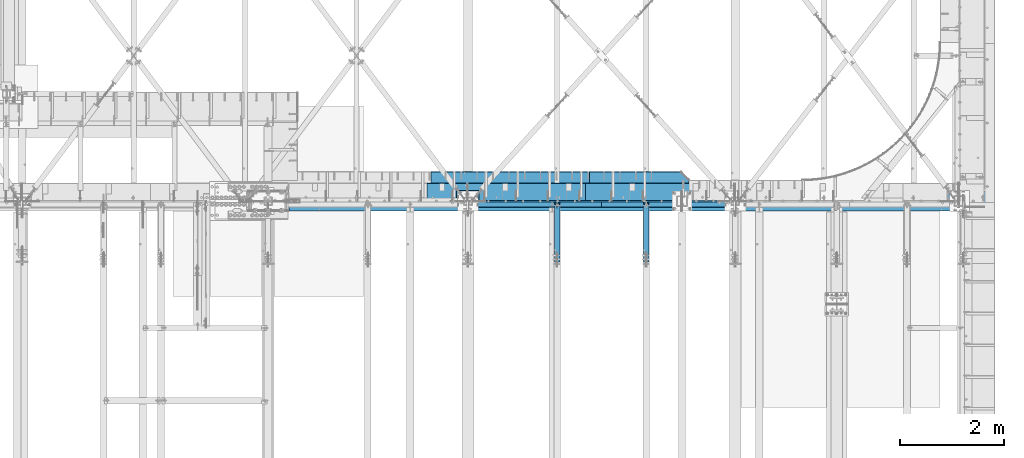
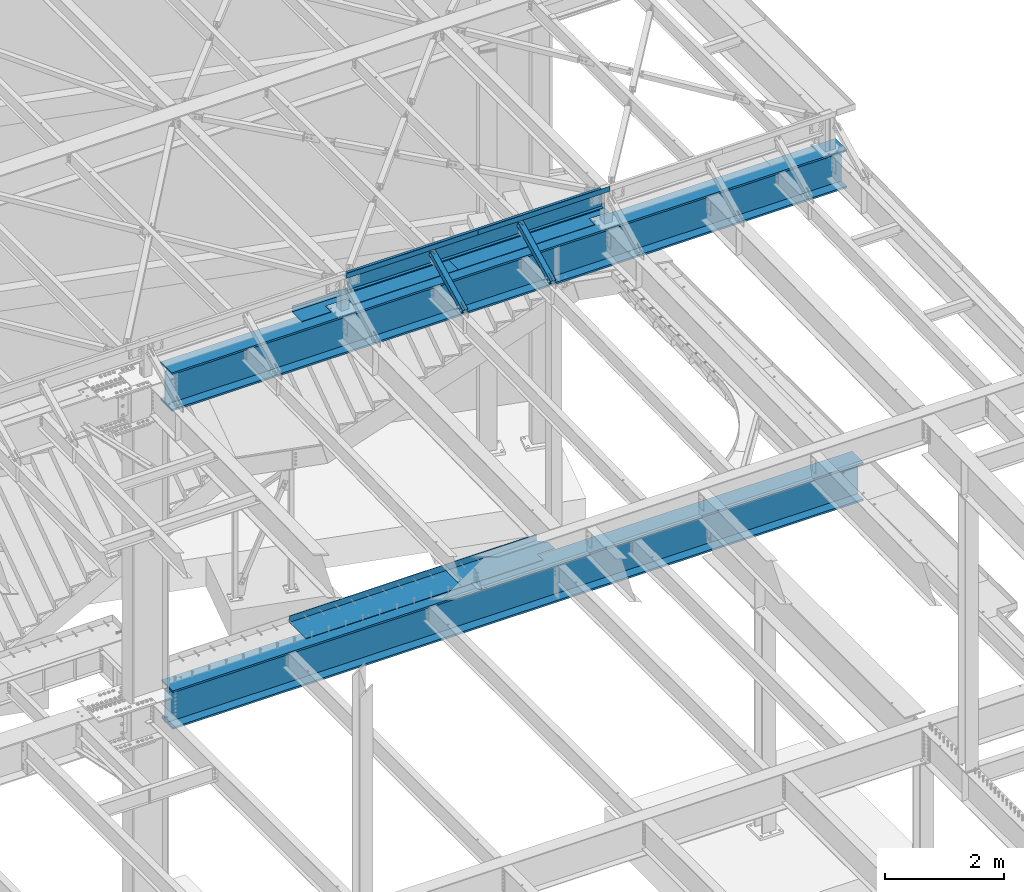
# One storey, part 1162 of 1763: 9 beams, 2 members, 5 elements without a shape of their own.
"""IFC2X3 building model written with IfcOpenShell, lengths in millimetres."""

import ifcopenshell
import ifcopenshell.guid

model = None  # the IFC model being written
_history = None  # IfcOwnerHistory: only IFC2X3 demands one
_inside = {}  # id of a spatial element -> (the spatial element, [elements in it])
_under = {}  # id of a project, library or spatial element -> (it, [spatial elements below it])
_declared = {}  # id of a project -> (the project, [libraries it declares])
_typed = {}  # id of a type object -> (the type object, [elements of that type])
_made_of = {}  # id of a material, layer set ... -> (it, [elements and type objects made of it])


def new_model(schema):
    """Start an empty IFC model of exactly this schema.

    Asked for "IFC4X3", IfcOpenShell would pick the latest addendum, in which some entities
    have other attributes; the version numbers below select the first issue.
    IFC2X3 requires an IfcOwnerHistory on every rooted entity: one is made here for all.
    """
    global model, _history
    if schema == "IFC4X3":
        model = ifcopenshell.file(schema_version=(4, 3, 0, 0))
    else:
        model = ifcopenshell.file(schema=schema)
    _inside.clear()
    _under.clear()
    _declared.clear()
    _typed.clear()
    _made_of.clear()
    _history = None
    if model.schema == "IFC2X3":
        org = make("IfcOrganization", Name="unknown")
        user = make(
            "IfcPersonAndOrganization",
            ThePerson=make("IfcPerson", FamilyName="unknown"),
            TheOrganization=org,
        )
        app = make(
            "IfcApplication",
            ApplicationDeveloper=org,
            Version="unknown",
            ApplicationFullName="unknown",
            ApplicationIdentifier="unknown",
        )
        _history = make(
            "IfcOwnerHistory",
            OwningUser=user,
            OwningApplication=app,
            ChangeAction="ADDED",
            CreationDate=0,
        )
    return model


def make(cls, **values):
    """One entity of the class cls with the attributes given. An attribute that is None is left unset."""
    return model.create_entity(
        cls, **{name: value for name, value in values.items() if value is not None}
    )


def rooted(cls, **values):
    """An entity with a GlobalId (a new one), such as an element, a storey or a relation."""
    return make(cls, GlobalId=ifcopenshell.guid.new(), OwnerHistory=_history, **values)


def si_unit(unit_type, name, prefix=None):
    """IfcSIUnit, for example si_unit("LENGTHUNIT", "METRE", prefix="MILLI")."""
    return make("IfcSIUnit", UnitType=unit_type, Prefix=prefix, Name=name)


def assignment(units):
    """IfcUnitAssignment: the units of a project."""
    return None if units is None else make("IfcUnitAssignment", Units=units)


def point(xyz):
    """IfcCartesianPoint."""
    return None if xyz is None else make("IfcCartesianPoint", Coordinates=xyz)


def direction(xyz):
    """IfcDirection."""
    return None if xyz is None else make("IfcDirection", DirectionRatios=xyz)


def frame(location, z_axis=None, x_axis=None):
    """IfcAxis2Placement3D, a coordinate frame: its origin and axes. An axis left out is left unset."""
    return make(
        "IfcAxis2Placement3D",
        Location=point(location),
        Axis=direction(z_axis),
        RefDirection=direction(x_axis),
    )


def origin_with_axes():
    """The frame at (0, 0, 0) with the z axis (0, 0, 1) and the x axis (1, 0, 0) written out."""
    return frame((0.0, 0.0, 0.0), z_axis=(0.0, 0.0, 1.0), x_axis=(1.0, 0.0, 0.0))


def place(relative_to, where):
    """IfcLocalPlacement: puts the frame where relative to a parent placement (None: the world)."""
    return make(
        "IfcLocalPlacement", PlacementRelTo=relative_to, RelativePlacement=where
    )


def context(
    kind, dimensions, precision=None, world=None, true_north=None, identifier=None
):
    """IfcGeometricRepresentationContext, for example the 3D "Model" context."""
    return make(
        "IfcGeometricRepresentationContext",
        ContextIdentifier=identifier,
        ContextType=kind,
        CoordinateSpaceDimension=dimensions,
        Precision=precision,
        WorldCoordinateSystem=world,
        TrueNorth=true_north,
    )


def subcontext(parent, identifier, kind, view, scale=None):
    """IfcGeometricRepresentationSubContext, for example "Body" below "Model"."""
    return make(
        "IfcGeometricRepresentationSubContext",
        ContextIdentifier=identifier,
        ContextType=kind,
        ParentContext=parent,
        TargetScale=scale,
        TargetView=view,
    )


def project(units=None, contexts=None):
    """IfcProject with its units and contexts."""
    return rooted(
        "IfcProject",
        Name="project",
        RepresentationContexts=contexts,
        UnitsInContext=assignment(units),
    )


def spatial(cls, under=None, at=None, **own):
    """A site, building, storey or space (cls), placed at a placement, below another one or the project."""
    s = rooted(cls, ObjectPlacement=at, **own)
    if under is not None:
        _under.setdefault(under.id(), (under, []))[1].append(s)
    return s


def faces_of(points, faces, orient=None, outer=None):
    """IfcFace entities. A face is a list of loops; a loop is a list of indices into points, from 0.

    orient and outer hold one flag for each loop. By default every Orientation is true, the
    first loop of a face is its IfcFaceOuterBound and the others are IfcFaceBound.
    """
    made = []
    for i, loops in enumerate(faces):
        bounds = []
        for j, loop in enumerate(loops):
            is_outer = j == 0 if outer is None else outer[i][j]
            bounds.append(
                make(
                    "IfcFaceOuterBound" if is_outer else "IfcFaceBound",
                    Bound=make("IfcPolyLoop", Polygon=[points[k] for k in loop]),
                    Orientation=True if orient is None else orient[i][j],
                )
            )
        made.append(make("IfcFace", Bounds=bounds))
    return made


def faceted_brep(points, faces, orient=None, outer=None, voids=None):
    """IfcFacetedBrep: a solid bounded by flat faces; with voids (closed shells), ...WithVoids."""
    shared = [point(p) for p in points]
    hull = make("IfcClosedShell", CfsFaces=faces_of(shared, faces, orient, outer))
    if voids is None:
        return make("IfcFacetedBrep", Outer=hull)
    return make(
        "IfcFacetedBrepWithVoids",
        Outer=hull,
        Voids=[
            make(cls, CfsFaces=faces_of(shared, fs, o, b)) for cls, fs, o, b in voids
        ],
    )


def shape(context_of_items, identifier, shape_type, items):
    """IfcShapeRepresentation: the items that make up one representation, for example the "Body"."""
    return make(
        "IfcShapeRepresentation",
        ContextOfItems=context_of_items,
        RepresentationIdentifier=identifier,
        RepresentationType=shape_type,
        Items=items,
    )


def material(Name=None, Category=None):
    """IfcMaterial."""
    return make("IfcMaterial", Name=Name, Category=Category)


def made_of(thing, what):
    """Note that an element or type object is made of a material, layer set ...; save() writes the relation."""
    if what is not None:
        _made_of.setdefault(what.id(), (what, []))[1].append(thing)
    return thing


def type_object(cls, material=None, **own):
    """A type object (cls), such as IfcWallType, which elements share."""
    return made_of(rooted(cls, **own), material)


def element(
    cls,
    number,
    at=None,
    inside=None,
    cuts=None,
    type_object=None,
    material=None,
    context=None,
    identifier="Body",
    shape_type=None,
    held_by="IfcProductDefinitionShape",
    body=None,
    shapes=None,
    **own,
):
    """One element of the class cls, such as IfcWall. Its Tag is "e" and its number.

    at: its placement. inside: the storey or other place that contains it. cuts: it is an
    opening in that element (IfcRelVoidsElement). A single representation is given by context,
    identifier, shape_type and body (its items); several are given by shapes. held_by: the class
    of the entity that holds the representations. save() writes the other relations.
    """
    e = rooted(cls, Tag="e%d" % number, ObjectPlacement=at, **own)
    if body is not None:
        shapes = [shape(context, identifier, shape_type, body)]
    if shapes is not None:
        e.Representation = make(held_by, Representations=shapes)
    if inside is not None:
        _inside.setdefault(inside.id(), (inside, []))[1].append(e)
    if cuts is not None:
        rooted(
            "IfcRelVoidsElement", RelatingBuildingElement=cuts, RelatedOpeningElement=e
        )
    if type_object is not None:
        _typed.setdefault(type_object.id(), (type_object, []))[1].append(e)
    return made_of(e, material)


def aggregate(whole, parts):
    """IfcRelAggregates: a whole, such as a stair, and the parts it consists of."""
    return rooted("IfcRelAggregates", RelatingObject=whole, RelatedObjects=parts)


def save(model, path):
    """Write the relations noted so far, then the file.

    IfcRelAggregates (storeys below a building ...), IfcRelContainedInSpatialStructure (elements
    in a storey), IfcRelDefinesByType, IfcRelAssociatesMaterial and IfcRelDeclares: one each for
    every whole, place, type object, material and project.
    """
    for whole, parts in _under.values():
        aggregate(whole, parts)
    for where, things in _inside.values():
        rooted(
            "IfcRelContainedInSpatialStructure",
            RelatedElements=things,
            RelatingStructure=where,
        )
    for kind, things in _typed.values():
        rooted("IfcRelDefinesByType", RelatedObjects=things, RelatingType=kind)
    for what, things in _made_of.values():
        rooted("IfcRelAssociatesMaterial", RelatedObjects=things, RelatingMaterial=what)
    for by, libraries in _declared.values():
        rooted("IfcRelDeclares", RelatingContext=by, RelatedDefinitions=libraries)
    model.write(path)


model = new_model("IFC2X3")

# Units and contexts
model_context = context("Model", 3, precision=1e-05, world=origin_with_axes())
body_context = subcontext(model_context, "Body", "Model", "MODEL_VIEW")
ifc_project = project(units=[si_unit("LENGTHUNIT", "METRE", prefix="MILLI"), si_unit("AREAUNIT", "SQUARE_METRE"), si_unit("VOLUMEUNIT", "CUBIC_METRE"), si_unit("MASSUNIT", "GRAM", prefix="KILO"), si_unit("TIMEUNIT", "SECOND"), si_unit("PLANEANGLEUNIT", "RADIAN"), si_unit("SOLIDANGLEUNIT", "STERADIAN"), si_unit("THERMODYNAMICTEMPERATUREUNIT", "DEGREE_CELSIUS"), si_unit("LUMINOUSINTENSITYUNIT", "LUMEN")], contexts=[model_context])

# Site, building, storey
site_placement = place(None, origin_with_axes())
site = spatial("IfcSite", under=ifc_project, at=site_placement, CompositionType="ELEMENT")
building_placement = place(site_placement, origin_with_axes())
building = spatial("IfcBuilding", under=site, at=building_placement, Name="Undefined", CompositionType="ELEMENT")
storey_placement = place(building_placement, origin_with_axes())
storey = spatial("IfcBuildingStorey", under=building, at=storey_placement, Name="Undefined", CompositionType="ELEMENT", Elevation=0.0)

# Assembly, beams
assembly_1_placement = place(storey_placement, origin_with_axes())
assembly_1 = element("IfcElementAssembly", 1, at=assembly_1_placement, inside=storey, Name="BEAM", AssemblyPlace="NOTDEFINED", PredefinedType="RIGID_FRAME")
ifc_material_1 = material(Name="STEEL/A36")
beam_type_1 = type_object("IfcBeamType", Name="L4X4X1/4", PredefinedType="NOTDEFINED")
beam_1_placement = place(assembly_1_placement, frame((-28544.5496174484, 52050.95, 12496.8), z_axis=(0.0, 1.0, 0.0), x_axis=(1.0, 0.0, 0.0)))
beam_1 = element("IfcBeam", 2, at=beam_1_placement, type_object=beam_type_1, material=ifc_material_1, Name="V. BRACE", ObjectType="L4X4X1/4", context=body_context, shape_type="Brep", body=[
    faceted_brep([(-3.63797880709171e-11, 50.8000000000011, -50.8000000000538), (-1.96450855582952e-10, 50.8000000000393, 50.7999999999374), (2567.94, 50.7999999999993, 50.8000000000029), (2567.94, 50.7999999999993, -50.8000000000029), (-1.81898940354586e-10, 44.4500000000371, 50.7999999999374), (2567.94, 44.4500000000007, 50.8000000000029), (-2.18278728425503e-11, 44.4500000000007, -44.450000000048), (2567.94, 44.4500000000007, -44.4499999999971), (1.96450855582952e-10, -50.8000000000338, -44.4499999999534), (2567.94, -50.7999999999993, -44.4499999999971), (2.11002770811319e-10, -50.8000000000357, -50.799999999952), (2567.94, -50.7999999999993, -50.8000000000029)], [[[0, 1, 2, 3]], [[1, 4, 5, 2]], [[4, 6, 7, 5]], [[6, 8, 9, 7]], [[8, 10, 11, 9]], [[10, 0, 3, 11]], [[5, 7, 9, 11, 3, 2]], [[10, 8, 6, 4, 1, 0]]]),
])
beam_2_placement = place(assembly_1_placement, frame((-31112.4896174537, 52050.9499997281, 12496.8), z_axis=(0.0, 1.0, 0.0), x_axis=(1.0, 0.0, 0.0)))
beam_2 = element("IfcBeam", 3, at=beam_2_placement, type_object=beam_type_1, material=ifc_material_1, Name="V. BRACE", ObjectType="L4X4X1/4", context=body_context, shape_type="Brep", body=[
    faceted_brep([(-3.63797880709171e-11, 50.8000000000011, -50.8000000000538), (-1.96450855582952e-10, 50.8000000000393, 50.7999999999374), (2567.94, 50.7999999999993, 50.8000000000029), (2567.94, 50.7999999999993, -50.8000000000029), (-1.81898940354586e-10, 44.4500000000371, 50.7999999999374), (2567.94, 44.4500000000007, 50.8000000000029), (-2.18278728425503e-11, 44.4500000000007, -44.450000000048), (2567.94, 44.4500000000007, -44.4499999999971), (1.96450855582952e-10, -50.8000000000338, -44.4499999999534), (2567.94, -50.7999999999993, -44.4499999999971), (2.11002770811319e-10, -50.8000000000357, -50.799999999952), (2567.94, -50.7999999999993, -50.8000000000029)], [[[0, 1, 2, 3]], [[1, 4, 5, 2]], [[4, 6, 7, 5]], [[6, 8, 9, 7]], [[8, 10, 11, 9]], [[10, 0, 3, 11]], [[5, 7, 9, 11, 3, 2]], [[10, 8, 6, 4, 1, 0]]]),
])

# Assembly, member
assembly_2_placement = place(storey_placement, origin_with_axes())
assembly_2 = element("IfcElementAssembly", 4, at=assembly_2_placement, inside=storey, Name="BEAM", AssemblyPlace="NOTDEFINED", PredefinedType="RIGID_FRAME")
ifc_material_2 = material()
member_type = type_object("IfcMemberType", Name="HSS4X4X1/2", PredefinedType="NOTDEFINED")
member_1_placement = place(assembly_2_placement, frame((-27687.5096174484, 50822.4762411655, 11720.6381213767), z_axis=(-1.0, 0.0, 0.0), x_axis=(0.0, 0.894427191199916, 0.447213595099959)))
member_1 = element("IfcMember", 5, at=member_1_placement, type_object=member_type, material=ifc_material_2, Name="BEAM", ObjectType="HSS4X4X1/2", context=body_context, shape_type="Brep", body=[
    faceted_brep([(1394.22226894295, -50.8000000020184, -7.9375), (1394.2222689429, -38.1000000020122, -7.9375), (1321.53025774739, -38.1000000019103, -7.9375), (1327.88025774027, -50.8000000019219, -7.9375), (1321.53025774739, -38.1000000019103, 7.9375), (1327.88025774027, -50.8000000019219, 7.9375), (1394.22226894295, -50.8000000020184, 7.9375), (1394.2222689429, -38.1000000020122, 7.9375), (1394.22226894266, 38.0999999980304, -7.9375), (1394.22226894262, 50.799999998042, -7.9375), (1277.08025779721, 50.7999999982076, -7.9375), (1283.4302577901, 38.0999999981887, -7.9375), (1277.08025779721, 50.7999999982076, 7.9375), (1283.4302577901, 38.0999999981887, 7.9375), (1394.22226894266, 38.0999999980304, 7.9375), (1394.22226894262, 50.799999998042, 7.9375), (166.342448712407, -38.100000000255, 38.0999999999985), (166.342448712276, 38.0999999997875, 38.0999999999985), (1394.22226894266, 38.0999999980304, 38.0999999999985), (1394.2222689429, -38.1000000020122, 38.0999999999985), (1394.2222689429, -38.1000000020122, -38.0999999999985), (166.342448712407, -38.100000000255, -38.0999999999985), (166.342448712407, -38.100000000255, -7.93749999974898), (317.154945941751, -38.1000000004715, -7.93749999987267), (320.192495686126, -38.1000000004769, -7.33329378918279), (322.767606017376, -38.1000000004806, -5.61266007554514), (324.488239731007, -38.1000000004842, -3.03754974427284), (325.092445941693, -38.1000000004842, 2.5465851649642e-10), (324.488239731007, -38.1000000004842, 3.03754974465119), (322.767606017376, -38.1000000004806, 5.61266007592349), (320.192495686126, -38.1000000004788, 7.33329378956478), (317.154945941751, -38.1000000004733, 7.93750000025466), (166.342448712407, -38.100000000255, 7.93750000025466), (166.342448712276, 38.0999999997875, -38.0999999999985), (1394.22226894266, 38.0999999980304, -38.0999999999985), (166.342448712276, 38.0999999997875, 7.93750000025466), (166.342448712254, 50.7999999997955, 7.93750000025466), (317.154945941591, 50.7999999995791, 7.93750000025466), (317.15494594162, 38.0999999995711, 7.93750000025466), (320.192495685966, 50.7999999995736, 7.33329378956478), (320.192495685995, 38.0999999995693, 7.33329378956478), (322.767606017216, 50.7999999995718, 5.61266007592349), (322.767606017245, 38.0999999995638, 5.61266007592349), (324.488239730847, 50.7999999995682, 3.03754974465119), (324.488239730868, 38.0999999995638, 3.03754974465119), (325.092445941533, 50.7999999995682, 2.5465851649642e-10), (325.092445941555, 38.0999999995583, 2.5465851649642e-10), (324.488239730847, 50.7999999995682, -3.03754974427284), (324.488239730861, 38.0999999995602, -3.03754974427284), (322.767606017209, 50.79999999957, -5.61266007554514), (322.767606017245, 38.0999999995638, -5.61266007554514), (320.192495685966, 50.7999999995754, -7.33329378918279), (320.19249568598, 38.0999999995674, -7.33329378918279), (317.154945941591, 50.7999999995791, -7.93749999987267), (317.154945941606, 38.0999999995693, -7.93749999987267), (166.342448712254, 50.7999999997955, -7.93749999974898), (166.342448712276, 38.0999999997875, -7.93749999974898), (166.342448712254, 50.7999999997955, -50.7999999999993), (166.342448712421, -50.8000000002612, -50.7999999999993), (166.342448712421, -50.8000000002612, -7.93749999974898), (317.154945941773, -50.8000000004795, -7.93749999987267), (320.192495686155, -50.8000000004831, -7.33329378918279), (322.767606017391, -50.8000000004868, -5.61266007554514), (324.488239731028, -50.800000000494, -3.03754974427284), (325.092445941715, -50.8000000004904, 2.5465851649642e-10), (324.488239731028, -50.800000000494, 3.03754974465119), (322.767606017405, -50.8000000004849, 5.61266007592349), (320.192495686155, -50.8000000004849, 7.33329378956478), (317.154945941787, -50.8000000004795, 7.93750000025466), (166.342448712421, -50.8000000002612, 7.93750000025466), (166.342448712421, -50.8000000002612, 50.7999999999993), (166.342448712254, 50.7999999997955, 50.7999999999993), (1394.22226894295, -50.8000000020184, 50.7999999999993), (1394.22226894262, 50.799999998042, 50.7999999999993), (1394.22226894262, 50.799999998042, -50.7999999999993), (1394.22226894295, -50.8000000020184, -50.7999999999993)], [[[0, 1, 2, 3]], [[3, 2, 4, 5]], [[6, 5, 4, 7]], [[8, 9, 10, 11]], [[11, 10, 12, 13]], [[14, 13, 12, 15]], [[16, 17, 18, 19]], [[2, 1, 20, 21, 22, 23, 24, 25, 26, 27, 28, 29, 30, 31, 32, 16, 19, 7, 4]], [[33, 21, 20, 34]], [[35, 36, 37, 38]], [[38, 37, 39, 40]], [[40, 39, 41, 42]], [[42, 41, 43, 44]], [[44, 43, 45, 46]], [[46, 45, 47, 48]], [[48, 47, 49, 50]], [[50, 49, 51, 52]], [[52, 51, 53, 54]], [[54, 53, 55, 56]], [[21, 33, 56, 55, 57, 58, 59, 22]], [[60, 23, 22, 59]], [[61, 24, 23, 60]], [[62, 25, 24, 61]], [[63, 26, 25, 62]], [[64, 27, 26, 63]], [[65, 28, 27, 64]], [[66, 29, 28, 65]], [[67, 30, 29, 66]], [[68, 31, 30, 67]], [[69, 32, 31, 68]], [[70, 71, 36, 35, 17, 16, 32, 69]], [[71, 70, 72, 73]], [[19, 18, 14, 15, 73, 72, 6, 7]], [[10, 9, 74, 57, 55, 53, 51, 49, 47, 45, 43, 41, 39, 37, 36, 71, 73, 15, 12]], [[58, 57, 74, 75]], [[72, 70, 69, 68, 67, 66, 65, 64, 63, 62, 61, 60, 59, 58, 75, 0, 3, 5, 6]], [[75, 74, 9, 8, 34, 20, 1, 0]], [[18, 17, 35, 38, 40, 42, 44, 46, 48, 50, 52, 54, 56, 33, 34, 8, 11, 13, 14]]]),
])
aggregate(assembly_2, [member_1])

assembly_3_placement = place(storey_placement, origin_with_axes())
assembly_3 = element("IfcElementAssembly", 6, at=assembly_3_placement, inside=storey, Name="BEAM", AssemblyPlace="NOTDEFINED", PredefinedType="RIGID_FRAME")
member_2_placement = place(assembly_3_placement, frame((-29398.4096174484, 50822.476241127, 11720.6381213765), z_axis=(-1.0, 0.0, 0.0), x_axis=(0.0, 0.894427191199916, 0.447213595099959)))
member_2 = element("IfcMember", 7, at=member_2_placement, type_object=member_type, material=ifc_material_2, Name="BEAM", ObjectType="HSS4X4X1/2", context=body_context, shape_type="Brep", body=[
    faceted_brep([(1394.22226894295, -50.8000000020184, -7.9375), (1394.2222689429, -38.1000000020122, -7.9375), (1321.53025774739, -38.1000000019103, -7.9375), (1327.88025774027, -50.8000000019219, -7.9375), (1321.53025774739, -38.1000000019103, 7.9375), (1327.88025774027, -50.8000000019219, 7.9375), (1394.22226894295, -50.8000000020184, 7.9375), (1394.2222689429, -38.1000000020122, 7.9375), (1394.22226894266, 38.0999999980304, -7.9375), (1394.22226894262, 50.799999998042, -7.9375), (1277.08025779721, 50.7999999982076, -7.9375), (1283.4302577901, 38.0999999981887, -7.9375), (1277.08025779721, 50.7999999982076, 7.9375), (1283.4302577901, 38.0999999981887, 7.9375), (1394.22226894266, 38.0999999980304, 7.9375), (1394.22226894262, 50.799999998042, 7.9375), (166.342448712407, -38.100000000255, 38.0999999999985), (166.342448712276, 38.0999999997875, 38.0999999999985), (1394.22226894266, 38.0999999980304, 38.0999999999985), (1394.2222689429, -38.1000000020122, 38.0999999999985), (1394.2222689429, -38.1000000020122, -38.0999999999985), (166.342448712407, -38.100000000255, -38.0999999999985), (166.342448712407, -38.100000000255, -7.93749999974898), (317.154945941751, -38.1000000004715, -7.93749999987267), (320.192495686126, -38.1000000004769, -7.33329378918279), (322.767606017376, -38.1000000004806, -5.61266007554514), (324.488239731007, -38.1000000004842, -3.03754974427284), (325.092445941693, -38.1000000004842, 2.5465851649642e-10), (324.488239731007, -38.1000000004842, 3.03754974465119), (322.767606017376, -38.1000000004806, 5.61266007592349), (320.192495686126, -38.1000000004788, 7.33329378956478), (317.154945941751, -38.1000000004733, 7.93750000025466), (166.342448712407, -38.100000000255, 7.93750000025466), (166.342448712276, 38.0999999997875, -38.0999999999985), (1394.22226894266, 38.0999999980304, -38.0999999999985), (166.342448712276, 38.0999999997875, 7.93750000025466), (166.342448712254, 50.7999999997955, 7.93750000025466), (317.154945941591, 50.7999999995791, 7.93750000025466), (317.15494594162, 38.0999999995711, 7.93750000025466), (320.192495685966, 50.7999999995736, 7.33329378956478), (320.192495685995, 38.0999999995693, 7.33329378956478), (322.767606017216, 50.7999999995718, 5.61266007592349), (322.767606017245, 38.0999999995638, 5.61266007592349), (324.488239730847, 50.7999999995682, 3.03754974465119), (324.488239730868, 38.0999999995638, 3.03754974465119), (325.092445941533, 50.7999999995682, 2.5465851649642e-10), (325.092445941555, 38.0999999995583, 2.5465851649642e-10), (324.488239730847, 50.7999999995682, -3.03754974427284), (324.488239730861, 38.0999999995602, -3.03754974427284), (322.767606017209, 50.79999999957, -5.61266007554514), (322.767606017245, 38.0999999995638, -5.61266007554514), (320.192495685966, 50.7999999995754, -7.33329378918279), (320.19249568598, 38.0999999995674, -7.33329378918279), (317.154945941591, 50.7999999995791, -7.93749999987267), (317.154945941606, 38.0999999995693, -7.93749999987267), (166.342448712254, 50.7999999997955, -7.93749999974898), (166.342448712276, 38.0999999997875, -7.93749999974898), (166.342448712254, 50.7999999997955, -50.7999999999993), (166.342448712421, -50.8000000002612, -50.7999999999993), (166.342448712421, -50.8000000002612, -7.93749999974898), (317.154945941773, -50.8000000004795, -7.93749999987267), (320.192495686155, -50.8000000004831, -7.33329378918279), (322.767606017391, -50.8000000004868, -5.61266007554514), (324.488239731028, -50.800000000494, -3.03754974427284), (325.092445941715, -50.8000000004904, 2.5465851649642e-10), (324.488239731028, -50.800000000494, 3.03754974465119), (322.767606017405, -50.8000000004849, 5.61266007592349), (320.192495686155, -50.8000000004849, 7.33329378956478), (317.154945941787, -50.8000000004795, 7.93750000025466), (166.342448712421, -50.8000000002612, 7.93750000025466), (166.342448712421, -50.8000000002612, 50.7999999999993), (166.342448712254, 50.7999999997955, 50.7999999999993), (1394.22226894295, -50.8000000020184, 50.7999999999993), (1394.22226894262, 50.799999998042, 50.7999999999993), (1394.22226894262, 50.799999998042, -50.7999999999993), (1394.22226894295, -50.8000000020184, -50.7999999999993)], [[[0, 1, 2, 3]], [[3, 2, 4, 5]], [[6, 5, 4, 7]], [[8, 9, 10, 11]], [[11, 10, 12, 13]], [[14, 13, 12, 15]], [[16, 17, 18, 19]], [[2, 1, 20, 21, 22, 23, 24, 25, 26, 27, 28, 29, 30, 31, 32, 16, 19, 7, 4]], [[33, 21, 20, 34]], [[35, 36, 37, 38]], [[38, 37, 39, 40]], [[40, 39, 41, 42]], [[42, 41, 43, 44]], [[44, 43, 45, 46]], [[46, 45, 47, 48]], [[48, 47, 49, 50]], [[50, 49, 51, 52]], [[52, 51, 53, 54]], [[54, 53, 55, 56]], [[21, 33, 56, 55, 57, 58, 59, 22]], [[60, 23, 22, 59]], [[61, 24, 23, 60]], [[62, 25, 24, 61]], [[63, 26, 25, 62]], [[64, 27, 26, 63]], [[65, 28, 27, 64]], [[66, 29, 28, 65]], [[67, 30, 29, 66]], [[68, 31, 30, 67]], [[69, 32, 31, 68]], [[70, 71, 36, 35, 17, 16, 32, 69]], [[71, 70, 72, 73]], [[19, 18, 14, 15, 73, 72, 6, 7]], [[10, 9, 74, 57, 55, 53, 51, 49, 47, 45, 43, 41, 39, 37, 36, 71, 73, 15, 12]], [[58, 57, 74, 75]], [[72, 70, 69, 68, 67, 66, 65, 64, 63, 62, 61, 60, 59, 58, 75, 0, 3, 5, 6]], [[75, 74, 9, 8, 34, 20, 1, 0]], [[18, 17, 35, 38, 40, 42, 44, 46, 48, 50, 52, 54, 56, 33, 34, 8, 11, 13, 14]]]),
])
aggregate(assembly_3, [member_2])

# Beam
ifc_material_3 = material(Name="STEEL/A992")
beam_type_2 = type_object("IfcBeamType", Name="W14X22", PredefinedType="NOTDEFINED")
beam_3_placement = place(assembly_1_placement, frame((-31112.4896174484, 52120.8, 12271.375), z_axis=(0.0, 0.0, 1.0), x_axis=(1.0, 0.0, 0.0)))
beam_3 = element("IfcBeam", 8, at=beam_3_placement, type_object=beam_type_2, material=ifc_material_3, Name="BEAM", ObjectType="W14X22", context=body_context, shape_type="Brep", body=[
    faceted_brep([(92.0749999948312, 63.5, -174.625), (92.0749999948312, 63.5, -166.6875), (5046.98000000045, 63.5, -166.6875), (5046.98000000045, 63.5, -174.625), (92.0749999948312, 3.17500000000291, -166.6875), (5046.98000000045, 3.17500000000291, -166.6875), (92.0749999948312, 3.17500000000291, 166.6875), (5046.98000000045, 3.17500000000291, 166.6875), (92.0749999948312, 63.5, 166.6875), (5046.98000000045, 63.5, 166.6875), (92.0749999948312, 63.5, 174.625), (5046.98000000045, 63.5, 174.625), (92.0749999948312, -63.5, 174.625), (5046.98000000045, -63.5, 174.625), (92.0749999948312, -63.5, 166.6875), (5046.98000000045, -63.5, 166.6875), (92.0749999948312, -3.17500000000291, 166.6875), (5046.98000000045, -3.17500000000291, 166.6875), (92.0749999948312, -3.17500000000291, -166.6875), (5046.98000000045, -3.17500000000291, -166.6875), (92.0749999948312, -63.5, -166.6875), (5046.98000000045, -63.5, -166.6875), (92.0749999948312, -63.5, -174.625), (5046.98000000045, -63.5, -174.625)], [[[0, 1, 2, 3]], [[1, 4, 5, 2]], [[4, 6, 7, 5]], [[6, 8, 9, 7]], [[8, 10, 11, 9]], [[10, 12, 13, 11]], [[12, 14, 15, 13]], [[14, 16, 17, 15]], [[16, 18, 19, 17]], [[18, 20, 21, 19]], [[20, 22, 23, 21]], [[22, 0, 3, 23]], [[5, 7, 9, 11, 13, 15, 17, 19, 21, 23, 3, 2]], [[22, 20, 18, 16, 14, 12, 10, 8, 6, 4, 1, 0]]]),
])

aggregate(assembly_1, [beam_1, beam_2, beam_3])

# Assembly, beams
assembly_4_placement = place(storey_placement, origin_with_axes())
assembly_4 = element("IfcElementAssembly", 9, at=assembly_4_placement, inside=storey, Name="BEAM", AssemblyPlace="NOTDEFINED", PredefinedType="RIGID_FRAME")
beam_type_3 = type_object("IfcBeamType", PredefinedType="NOTDEFINED")
beam_4_placement = place(assembly_4_placement, frame((-27326.6617736984, 52133.5000002128, 11752.2624917654), z_axis=(-1.0, 0.0, 0.0), x_axis=(0.0, 1.0, 0.0)))
beam_4 = element("IfcBeam", 10, at=beam_4_placement, type_object=beam_type_3, material=ifc_material_1, Name="BENT_PLATE", context=body_context, shape_type="Brep", body=[
    faceted_brep([(193.674999999996, -4.76250000000073, -1134.15215319826), (193.674999999996, 4.76250000000073, -1134.15215319826), (193.674999999988, 4.76250000000073, -1524.0), (193.674999999988, -4.76250000000073, -1524.0), (0.0, -4.76250000000073, -1134.15215319825), (0.0, 4.76250000000073, -1134.15215319825), (336.549987792969, 4.76250000000073, 1524.0), (0.0, 4.76249999999982, 1524.0), (0.0, -4.76249999999982, 1524.0), (327.024987792967, -4.76250000000073, 1524.00000000001), (327.024987792975, -122.237499999999, 1524.0), (336.549987792969, -122.237499999999, 1524.0), (336.549987792969, 4.76250000000073, -1524.0), (336.549987792969, -122.237499999999, -1524.0), (327.024987792975, -122.237499999999, -1524.0), (327.024987792975, -4.76250000000073, -1524.0)], [[[0, 1, 2, 3]], [[4, 5, 1, 0]], [[6, 7, 8, 9, 10, 11]], [[12, 6, 11, 13]], [[10, 14, 13, 11]], [[9, 15, 14, 10]], [[12, 13, 14, 15, 3, 2]], [[7, 6, 12, 2, 1, 5]], [[8, 7, 5, 4]], [[15, 9, 8, 4, 0, 3]]]),
])
beam_5_placement = place(assembly_4_placement, frame((-30374.6617736984, 52133.5000002128, 11752.2624917654), z_axis=(-1.0, 0.0, 0.0), x_axis=(0.0, 1.0, 0.0)))
beam_5 = element("IfcBeam", 11, at=beam_5_placement, type_object=beam_type_3, material=ifc_material_1, Name="BENT_PLATE", context=body_context, shape_type="Brep", body=[
    faceted_brep([(193.674999999988, -4.76250000000073, 521.927828491207), (193.674999999988, 4.76250000000073, 521.927828491207), (0.0, 4.76250000000073, 521.927828491207), (0.0, -4.76250000000073, 521.927828491207), (193.674999999988, -4.76250000000073, 953.727846801754), (193.674999999988, 4.76250000000073, 953.727846801754), (0.0, -4.76250000000073, 953.727846801754), (0.0, 4.76250000000073, 953.727846801754), (327.024987792967, -4.76250000000073, 1524.00000000001), (327.024987792975, -4.76250000000073, -1524.0), (327.024987792975, -122.237499999999, -1524.0), (327.024987792975, -122.237499999999, 1524.0), (336.549987792969, 4.76250000000073, 1524.0), (0.0, 4.76249999999982, 1524.0), (0.0, -4.76249999999982, 1524.0), (336.549987792969, -122.237499999999, 1524.0), (336.549987792969, 4.76250000000073, -1524.0), (336.549987792969, -122.237499999999, -1524.0), (0.0, -4.76249999999982, -1524.0), (0.0, 4.76249999999982, -1524.0)], [[[0, 1, 2, 3]], [[4, 5, 1, 0]], [[6, 7, 5, 4]], [[8, 9, 10, 11]], [[12, 13, 14, 8, 11, 15]], [[16, 12, 15, 17]], [[11, 10, 17, 15]], [[9, 18, 19, 16, 17, 10]], [[19, 18, 3, 2]], [[13, 12, 16, 19, 2, 1, 5, 7]], [[14, 13, 7, 6]], [[3, 18, 9, 8, 14, 6, 4, 0]]]),
])

assembly_5_placement = place(storey_placement, origin_with_axes())
assembly_5 = element("IfcElementAssembly", 12, at=assembly_5_placement, inside=storey, Name="BEAM", AssemblyPlace="NOTDEFINED", PredefinedType="RIGID_FRAME")
beam_type_4 = type_object("IfcBeamType", PredefinedType="NOTDEFINED")
beam_6_placement = place(assembly_5_placement, frame((-27819.5812736984, 52131.1187449422, 5199.0625), z_axis=(1.0, 0.0, 0.0), x_axis=(0.0, 1.0, 0.0)))
beam_6 = element("IfcBeam", 13, at=beam_6_placement, type_object=beam_type_4, material=ifc_material_1, Name="BENT PLATE", context=body_context, shape_type="Brep", body=[
    faceted_brep([(548.45809615848, -4.76249999999982, 807.253370332601), (548.4812866211, 4.76249999999982, 807.253370332601), (397.600884329186, 4.76249999999982, 958.056), (397.600884329186, -4.76249999999982, 958.056), (558.006281758295, -4.76249999999982, 807.253371303246), (558.006286621094, 134.937496948242, 807.253371303246), (548.4812866211, 134.937496948242, 807.253370332601), (192.88228943383, -4.76249999999982, 958.056), (192.88228943383, 4.76249999999982, 958.056), (192.881255054956, 4.76249999999982, 616.743572528056), (192.881255054956, -4.76249999999982, 616.743572528056), (0.0, 4.76249999999982, 616.744591326536), (0.0, -4.76249999999982, 616.744591326536), (0.0, 4.76249999999982, -958.056), (0.0, -4.76249999999982, -958.056), (558.006286621094, -4.76249999999982, -958.056), (548.4812866211, 4.76249999999982, -958.056), (548.4812866211, 134.937496948242, -958.056), (558.006286621094, 134.937496948242, -958.056)], [[[0, 1, 2, 3]], [[4, 5, 6, 1, 0]], [[7, 8, 9, 10]], [[10, 9, 11, 12]], [[13, 14, 12, 11]], [[15, 14, 13, 16, 17, 18]], [[3, 7, 10, 12, 14, 15, 4, 0]], [[8, 7, 3, 2]], [[16, 13, 11, 9, 8, 2, 1]], [[17, 16, 1, 6]], [[18, 17, 6, 5]], [[15, 18, 5, 4]]]),
])
beam_7_placement = place(assembly_5_placement, frame((-30301.6372736984, 52131.1187449422, 5199.0625), z_axis=(1.0, 0.0, 0.0), x_axis=(0.0, 1.0, 0.0)))
beam_7 = element("IfcBeam", 14, at=beam_7_placement, type_object=beam_type_4, material=ifc_material_1, Name="BENT PLATE", context=body_context, shape_type="Brep", body=[
    faceted_brep([(0.0, -4.76249999999982, -1524.0), (0.0, -4.76249999999982, 1524.0), (0.0, 4.76249999999982, 1524.0), (0.0, 4.76249999999982, -1524.0), (548.4812866211, 4.76249999999982, 1524.0), (548.4812866211, 4.76249999999982, -1524.0), (558.006286621094, -4.76249999999982, -1524.0), (558.006286621094, -4.76249999999982, 1524.0), (548.4812866211, 134.937496948242, 1524.0), (548.4812866211, 134.937496948242, -1524.0), (558.006286621094, 134.937496948242, 1524.0), (558.006286621094, 134.937496948242, -1524.0)], [[[0, 1, 2, 3]], [[3, 2, 4, 5]], [[1, 0, 6, 7]], [[5, 4, 8, 9]], [[4, 2, 1, 7, 10, 8]], [[7, 6, 11, 10]], [[6, 0, 3, 5, 9, 11]], [[10, 11, 9, 8]]]),
])

# Beam
beam_type_5 = type_object("IfcBeamType", Name="W30X235", PredefinedType="NOTDEFINED")
beam_8_placement = place(assembly_4_placement, frame((-34949.8372736984, 52120.8000002128, 11350.6249917654), z_axis=(0.0, 0.0, 1.0), x_axis=(1.0, 0.0, 0.0)))
beam_8 = element("IfcBeam", 15, at=beam_8_placement, type_object=beam_type_5, material=ifc_material_3, Name="BEAM", ObjectType="W30X235", context=body_context, shape_type="Brep", body=[
    faceted_brep([(369.88749999999, -10.3187499999985, -320.935000000001), (369.88749999999, 10.3187499999985, -320.935000000001), (388.937500190732, 10.3187499999985, -320.935000000001), (388.937500190732, -10.3187499999985, -320.935000000001), (393.797579708778, 10.3187499999985, -321.901729922589), (393.797579708778, -10.3187499999985, -321.901729922589), (397.917756176932, 10.3187499999985, -324.654743823066), (397.917756176932, -10.3187499999985, -324.654743823066), (400.670770077406, 10.3187499999985, -328.77492029122), (400.670770077406, -10.3187499999985, -328.77492029122), (401.637499999997, -10.3187499999985, -333.634999809266), (401.637499999997, 10.3187499999985, -333.634999809266), (401.637499999997, 10.3187499999985, -358.775), (401.637499999997, 190.5, -358.775), (401.637499999997, 190.5, -396.875), (401.637499999997, -190.5, -396.875), (401.637499999997, -190.5, -358.775), (401.637499999997, -10.3187499999985, -358.775), (13546.49765625, -190.5, 358.775), (13546.49765625, -190.5, 396.875), (401.637499243006, -190.5, 396.875), (401.637499243006, -190.5, 358.775), (13546.49765625, 190.5, 396.875), (401.637499243006, 190.5, 396.875), (13546.49765625, 190.5, 358.775), (401.637499243006, 190.5, 358.775), (13546.49765625, 10.3187499999985, 358.775), (401.637499243006, 10.3187499999985, 358.775), (388.937499433741, -10.3187499999985, 320.414997863771), (388.937499433741, 10.3187499999985, 320.414997863771), (369.88749999999, 10.3187499999985, 320.414997863771), (369.88749999999, -10.3187499999985, 320.414997863771), (393.797578951788, -10.3187499999985, 321.381727786358), (393.797578951788, 10.3187499999985, 321.381727786358), (397.917755419941, -10.3187499999985, 324.134741686836), (397.917755419941, 10.3187499999985, 324.134741686836), (400.670769320415, -10.3187499999985, 328.254918154989), (400.670769320415, 10.3187499999985, 328.254918154989), (401.637499243006, -10.3187499999985, 333.114997673036), (401.637499243006, 10.3187499999985, 333.114997673036), (401.637499243006, -10.3187499999985, 358.775), (13546.49765625, -10.3187499999985, 358.775), (13546.49765625, 10.3187499999985, -358.775), (13546.49765625, -10.3187499999985, -358.775), (13546.49765625, -190.5, -358.775), (13546.49765625, -190.5, -396.875), (13546.49765625, 190.5, -396.875), (13546.49765625, 190.5, -358.775)], [[[0, 1, 2, 3]], [[3, 2, 4, 5]], [[5, 4, 6, 7]], [[7, 6, 8, 9]], [[10, 11, 12, 13, 14, 15, 16, 17]], [[9, 8, 11, 10]], [[18, 19, 20, 21]], [[19, 22, 23, 20]], [[22, 24, 25, 23]], [[24, 26, 27, 25]], [[28, 29, 30, 31]], [[32, 33, 29, 28]], [[34, 35, 33, 32]], [[36, 37, 35, 34]], [[38, 39, 37, 36]], [[20, 23, 25, 27, 39, 38, 40, 21]], [[41, 18, 21, 40]], [[42, 26, 24, 22, 19, 18, 41, 43, 44, 45, 46, 47]], [[44, 43, 17, 16]], [[45, 44, 16, 15]], [[46, 45, 15, 14]], [[47, 46, 14, 13]], [[42, 47, 13, 12]], [[6, 4, 2, 1, 30, 29, 33, 35, 37, 39, 27, 26, 42, 12, 11, 8]], [[31, 30, 1, 0]], [[43, 41, 40, 38, 36, 34, 32, 28, 31, 0, 3, 5, 7, 9, 10, 17]]]),
])

aggregate(assembly_4, [beam_4, beam_5, beam_8])

beam_9_placement = place(assembly_5_placement, frame((-34949.8372736984, 52120.8, 4797.425), z_axis=(0.0, 0.0, 1.0), x_axis=(1.0, 0.0, 0.0)))
beam_9 = element("IfcBeam", 16, at=beam_9_placement, type_object=beam_type_5, material=ifc_material_3, Name="BEAM", ObjectType="W30X235", context=body_context, shape_type="Brep", body=[
    faceted_brep([(369.88749999999, -10.3187499999985, -346.335), (369.88749999999, 10.3187499999985, -346.335), (407.987500190735, 10.3187499999985, -346.335), (407.987500190735, -10.3187499999985, -346.335), (412.847579708781, 10.3187499999985, -347.301729922588), (412.847579708781, -10.3187499999985, -347.301729922588), (416.967756176935, 10.3187499999985, -350.054743823066), (416.967756176935, -10.3187499999985, -350.054743823066), (419.720770077409, 10.3187499999985, -354.17492029122), (419.720770077409, -10.3187499999985, -354.17492029122), (420.6875, -190.5, -359.034999809265), (420.6875, 190.5, -359.034999809265), (420.6875, 190.5, -396.875), (420.6875, -190.5, -396.875), (420.635782822421, -190.5, -358.775), (420.635782822421, -10.3187499999985, -358.775), (420.635782822421, 10.3187499999985, -358.775), (420.635782822421, 190.5, -358.775), (13870.34765625, -190.5, 358.775), (13870.34765625, -190.5, 396.875), (420.6875, -190.5, 396.875), (420.6875, -190.5, 358.775), (13870.34765625, 190.5, 396.875), (420.6875, 190.5, 396.875), (13870.34765625, 190.5, 358.775), (420.6875, 190.5, 358.775), (13870.34765625, 10.3187499999985, 358.775), (420.6875, 10.3187499999985, 358.775), (407.987500190735, -10.3187499999985, 345.815001678467), (407.987500190735, 10.3187499999985, 345.815001678467), (369.88749999999, 10.3187499999985, 345.815001678467), (369.88749999999, -10.3187499999985, 345.815001678467), (412.847579708781, -10.3187499999985, 346.781731601054), (412.847579708781, 10.3187499999985, 346.781731601054), (416.967756176935, -10.3187499999985, 349.534745501533), (416.967756176935, 10.3187499999985, 349.534745501533), (419.720770077409, -10.3187499999985, 353.654921969686), (419.720770077409, 10.3187499999985, 353.654921969686), (420.6875, -10.3187499999985, 358.515001487732), (420.6875, 10.3187499999985, 358.515001487732), (420.6875, -10.3187499999985, 358.775), (13870.34765625, -10.3187499999985, 358.775), (13870.34765625, 10.3187499999985, -358.775), (13870.34765625, -10.3187499999985, -358.775), (13870.34765625, -190.5, -358.775), (13870.34765625, -190.5, -396.875), (13870.34765625, 190.5, -396.875), (13870.34765625, 190.5, -358.775)], [[[0, 1, 2, 3]], [[3, 2, 4, 5]], [[5, 4, 6, 7]], [[7, 6, 8, 9]], [[10, 11, 12, 13]], [[14, 15, 9, 8, 16, 17, 11, 10]], [[18, 19, 20, 21]], [[19, 22, 23, 20]], [[22, 24, 25, 23]], [[24, 26, 27, 25]], [[28, 29, 30, 31]], [[32, 33, 29, 28]], [[34, 35, 33, 32]], [[36, 37, 35, 34]], [[38, 39, 37, 36]], [[20, 23, 25, 27, 39, 38, 40, 21]], [[41, 18, 21, 40]], [[42, 26, 24, 22, 19, 18, 41, 43, 44, 45, 46, 47]], [[13, 45, 44, 14, 10]], [[46, 45, 13, 12]], [[47, 46, 12, 11, 17]], [[42, 47, 17, 16]], [[6, 4, 2, 1, 30, 29, 33, 35, 37, 39, 27, 26, 42, 16, 8]], [[31, 30, 1, 0]], [[43, 41, 40, 38, 36, 34, 32, 28, 31, 0, 3, 5, 7, 9, 15]], [[44, 43, 15, 14]]]),
])

aggregate(assembly_5, [beam_6, beam_7, beam_9])

save(model, "model.ifc")
